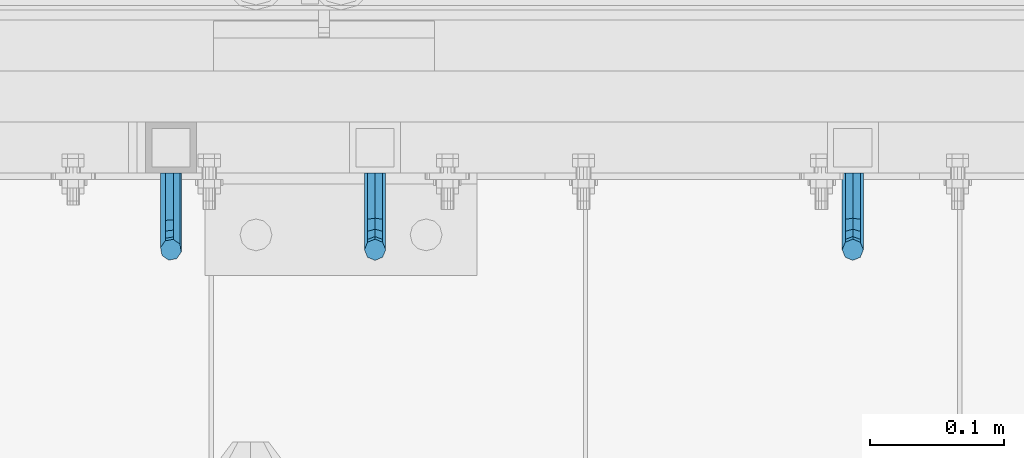
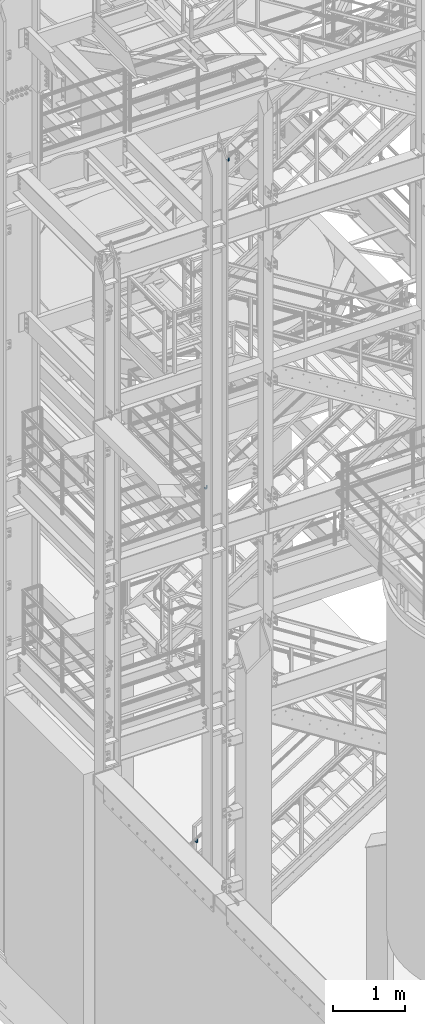
# One storey, part 1176 of 1876: 3 beams, 3 elements without a shape of their own.
"""IFC2X3 building model written with IfcOpenShell, lengths in millimetres."""

from ifc_helpers import new_model, si_unit, frame, origin_with_axes, place, context, subcontext, project, spatial, faceted_brep, material, type_object, element, aggregate, save


model = new_model("IFC2X3")

# Units and contexts
model_context = context("Model", 3, precision=1e-05, world=origin_with_axes())
body_context = subcontext(model_context, "Body", "Model", "MODEL_VIEW")
ifc_project = project(units=[si_unit("LENGTHUNIT", "METRE", prefix="MILLI"), si_unit("AREAUNIT", "SQUARE_METRE"), si_unit("VOLUMEUNIT", "CUBIC_METRE"), si_unit("MASSUNIT", "GRAM", prefix="KILO"), si_unit("TIMEUNIT", "SECOND"), si_unit("PLANEANGLEUNIT", "RADIAN"), si_unit("SOLIDANGLEUNIT", "STERADIAN"), si_unit("THERMODYNAMICTEMPERATUREUNIT", "DEGREE_CELSIUS"), si_unit("LUMINOUSINTENSITYUNIT", "LUMEN")], contexts=[model_context])

# Site, building, storey
site_placement = place(None, origin_with_axes())
site = spatial("IfcSite", under=ifc_project, at=site_placement, CompositionType="ELEMENT")
building_placement = place(site_placement, origin_with_axes())
building = spatial("IfcBuilding", under=site, at=building_placement, Name="Undefined", CompositionType="ELEMENT")
storey_placement = place(building_placement, origin_with_axes())
storey = spatial("IfcBuildingStorey", under=building, at=storey_placement, Name="Undefined", CompositionType="ELEMENT", Elevation=0.0)

# Assembly, beam
assembly_1_placement = place(storey_placement, origin_with_axes())
assembly_1 = element("IfcElementAssembly", 1, at=assembly_1_placement, inside=storey, Name="RAIL", AssemblyPlace="NOTDEFINED", PredefinedType="RIGID_FRAME")
ifc_material = material(Name="STEEL/A36")
beam_type = type_object("IfcBeamType", PredefinedType="NOTDEFINED")
beam_1_placement = place(assembly_1_placement, frame((3252.25833355881, -4800.59999885446, 12395.2930113215), z_axis=(1.0, 0.0, 0.0), x_axis=(0.0, -1.0, 0.0)))
beam_1 = element("IfcBeam", 2, at=beam_1_placement, type_object=beam_type, material=ifc_material, Name="BRACKET", context=body_context, shape_type="Brep", body=[
    faceted_brep([(0.0, -5.61266007566822, 5.61266007566883), (0.0, 0.0, 7.9375), (0.0, 5.61266007566822, 5.61266007566883), (0.0, 7.9375, 0.0), (0.0, 5.61266007566822, -5.61266007566883), (0.0, 0.0, -7.9375), (0.0, -5.61266007566822, -5.61266007566883), (0.0, -7.9375, 0.0), (23.8125, 5.61266007566883, 5.61266007566792), (23.8125, 7.9375, 0.0), (23.8125, 5.61266007566883, -5.61266007566792), (23.8125, 0.0, -7.9375), (23.8125, -5.61266007566883, -5.61266007566792), (23.8125, -7.9375, 0.0), (23.8125, -5.61266007566883, 5.61266007566792), (23.8125, 0.0, 7.9375), (36.5702095103989, -2.53766620105534, 7.9375), (38.7180815328547, 2.64775556579752, 5.61266007566792), (39.6077592547972, 4.79562758825296, 0.0), (38.7180815328547, 2.64775556579752, -5.61266007566792), (36.5702095103989, -2.53766620105534, -7.9375), (34.4223374879439, -7.72308796790867, -5.61266007566792), (33.5326597660014, -9.87095999036364, 0.0), (34.4223374879439, -7.72308796790867, 5.61266007566792), (43.4169233967659, -13.733078129113, 5.61266007566792), (47.385673396765, -9.76432812911298, 7.9375), (41.7730133210971, -15.3769882047809, 0.0), (43.4169233967659, -13.733078129113, -5.61266007566792), (47.385673396765, -9.76432812911298, -7.9375), (51.354423396765, -5.79557812911253, -5.61266007566792), (52.9983334724338, -4.15166805344461, 0.0), (51.354423396765, -5.79557812911253, 5.61266007566792), (54.6123353248231, -20.5797920154787, 7.9375), (59.7977570916764, -18.4319199930233, 5.61266007566792), (49.4269135579698, -22.7276640379341, 5.61266007566792), (47.2790415355148, -23.6173417598766, 0.0), (49.4269135579698, -22.7276640379341, -5.61266007566792), (54.6123353248231, -20.5797920154787, -7.9375), (59.7977570916764, -18.4319199930233, -5.61266007566792), (61.9456291141314, -17.5422422710808, 0.0), (62.7626616015468, -33.3375015258789, 5.61266007566792), (65.0875015258789, -33.3375015258789, 0.0), (57.1500015258789, -33.3375015258789, 7.9375), (51.5373414502101, -33.3375015258789, 5.61266007566792), (49.2125015258789, -33.3375015258789, 0.0), (51.5373414502101, -33.3375015258789, -5.61266007566792), (57.1500015258789, -33.3375015258789, -7.9375), (62.7626616015468, -33.3375015258789, -5.61266007566792), (65.0875015258789, -66.5341532333514, 2.45290721068159e-09), (62.7626616015805, -63.0815171359536, -5.61266007334871), (57.1500015259289, -61.6513884384531, -7.93749999776537), (51.5373414502437, -63.0815171359118, -5.6126600734151), (49.2125015258789, -66.5341532333259, 2.41197994910181e-09), (51.5373414501864, -69.9867893307037, 5.61266007818085), (57.1500015258471, -71.4169180281988, 7.93750000258842), (62.7626616015223, -69.9867893307346, 5.61266007822906)], [[[0, 1, 2, 3, 4, 5, 6, 7]], [[3, 2, 8, 9]], [[4, 3, 9, 10]], [[5, 4, 10, 11]], [[6, 5, 11, 12]], [[7, 6, 12, 13]], [[0, 7, 13, 14]], [[1, 0, 14, 15]], [[2, 1, 15, 8]], [[8, 15, 16, 17]], [[9, 8, 17, 18]], [[10, 9, 18, 19]], [[11, 10, 19, 20]], [[12, 11, 20, 21]], [[13, 12, 21, 22]], [[14, 13, 22, 23]], [[15, 14, 23, 16]], [[23, 24, 25, 16]], [[22, 26, 24, 23]], [[21, 27, 26, 22]], [[20, 28, 27, 21]], [[19, 29, 28, 20]], [[18, 30, 29, 19]], [[17, 31, 30, 18]], [[16, 25, 31, 17]], [[25, 32, 33, 31]], [[24, 34, 32, 25]], [[26, 35, 34, 24]], [[27, 36, 35, 26]], [[28, 37, 36, 27]], [[29, 38, 37, 28]], [[30, 39, 38, 29]], [[31, 33, 39, 30]], [[33, 40, 41, 39]], [[32, 42, 40, 33]], [[34, 43, 42, 32]], [[35, 44, 43, 34]], [[36, 45, 44, 35]], [[37, 46, 45, 36]], [[38, 47, 46, 37]], [[39, 41, 47, 38]], [[47, 41, 48, 49]], [[46, 47, 49, 50]], [[45, 46, 50, 51]], [[44, 45, 51, 52]], [[43, 44, 52, 53]], [[42, 43, 53, 54]], [[40, 42, 54, 55]], [[41, 40, 55, 48]], [[54, 53, 52, 51, 50, 49, 48, 55]]]),
])
aggregate(assembly_1, [beam_1])

assembly_2_placement = place(storey_placement, origin_with_axes())
assembly_2 = element("IfcElementAssembly", 3, at=assembly_2_placement, inside=storey, Name="RAIL", AssemblyPlace="NOTDEFINED", PredefinedType="RIGID_FRAME")
beam_2_placement = place(assembly_2_placement, frame((2895.60000031138, -4800.59999885446, 6951.80681178874), z_axis=(1.0, 0.0, 0.0), x_axis=(0.0, -1.0, 0.0)))
beam_2 = element("IfcBeam", 4, at=beam_2_placement, type_object=beam_type, material=ifc_material, Name="BRACKET", context=body_context, shape_type="Brep", body=[
    faceted_brep([(0.0, -5.61266007566822, 5.61266007566883), (0.0, 0.0, 7.9375), (0.0, 5.61266007566822, 5.61266007566883), (0.0, 7.9375, 0.0), (0.0, 5.61266007566822, -5.61266007566883), (0.0, 0.0, -7.9375), (0.0, -5.61266007566822, -5.61266007566883), (0.0, -7.9375, 0.0), (23.8125, 5.61266007566883, 5.61266007566792), (23.8125, 7.9375, 0.0), (23.8125, 5.61266007566883, -5.61266007566792), (23.8125, 0.0, -7.9375), (23.8125, -5.61266007566883, -5.61266007566792), (23.8125, -7.9375, 0.0), (23.8125, -5.61266007566883, 5.61266007566792), (23.8125, 0.0, 7.9375), (36.5702095103989, -2.53766620105534, 7.9375), (38.7180815328547, 2.64775556579752, 5.61266007566792), (39.6077592547972, 4.79562758825296, 0.0), (38.7180815328547, 2.64775556579752, -5.61266007566792), (36.5702095103989, -2.53766620105534, -7.9375), (34.4223374879439, -7.72308796790867, -5.61266007566792), (33.5326597660014, -9.87095999036364, 0.0), (34.4223374879439, -7.72308796790867, 5.61266007566792), (43.4169233967659, -13.733078129113, 5.61266007566792), (47.385673396765, -9.76432812911298, 7.9375), (41.7730133210971, -15.3769882047809, 0.0), (43.4169233967659, -13.733078129113, -5.61266007566792), (47.385673396765, -9.76432812911298, -7.9375), (51.354423396765, -5.79557812911253, -5.61266007566792), (52.9983334724338, -4.15166805344461, 0.0), (51.354423396765, -5.79557812911253, 5.61266007566792), (54.6123353248231, -20.5797920154787, 7.9375), (59.7977570916764, -18.4319199930233, 5.61266007566792), (49.4269135579698, -22.7276640379341, 5.61266007566792), (47.2790415355148, -23.6173417598766, 0.0), (49.4269135579698, -22.7276640379341, -5.61266007566792), (54.6123353248231, -20.5797920154787, -7.9375), (59.7977570916764, -18.4319199930233, -5.61266007566792), (61.9456291141314, -17.5422422710808, 0.0), (62.7626616015468, -33.3375015258789, 5.61266007566792), (65.0875015258789, -33.3375015258789, 0.0), (57.1500015258789, -33.3375015258789, 7.9375), (51.5373414502101, -33.3375015258789, 5.61266007566792), (49.2125015258789, -33.3375015258789, 0.0), (51.5373414502101, -33.3375015258789, -5.61266007566792), (57.1500015258789, -33.3375015258789, -7.9375), (62.7626616015468, -33.3375015258789, -5.61266007566792), (65.0875015258789, -66.3198535804604, 0.0), (62.7626616015468, -62.7481608643047, -5.61266007566792), (57.1500015258789, -61.2687173006434, -7.9375), (51.537341450211, -62.7481608643047, -5.61266007566792), (49.2125015258789, -66.3198535804604, 0.0), (51.537341450211, -69.8915462966161, 5.61266007566792), (57.1500015258789, -71.3709898602756, 7.9375), (62.7626616015468, -69.8915462966161, 5.61266007566792)], [[[0, 1, 2, 3, 4, 5, 6, 7]], [[3, 2, 8, 9]], [[4, 3, 9, 10]], [[5, 4, 10, 11]], [[6, 5, 11, 12]], [[7, 6, 12, 13]], [[0, 7, 13, 14]], [[1, 0, 14, 15]], [[2, 1, 15, 8]], [[8, 15, 16, 17]], [[9, 8, 17, 18]], [[10, 9, 18, 19]], [[11, 10, 19, 20]], [[12, 11, 20, 21]], [[13, 12, 21, 22]], [[14, 13, 22, 23]], [[15, 14, 23, 16]], [[23, 24, 25, 16]], [[22, 26, 24, 23]], [[21, 27, 26, 22]], [[20, 28, 27, 21]], [[19, 29, 28, 20]], [[18, 30, 29, 19]], [[17, 31, 30, 18]], [[16, 25, 31, 17]], [[25, 32, 33, 31]], [[24, 34, 32, 25]], [[26, 35, 34, 24]], [[27, 36, 35, 26]], [[28, 37, 36, 27]], [[29, 38, 37, 28]], [[30, 39, 38, 29]], [[31, 33, 39, 30]], [[33, 40, 41, 39]], [[32, 42, 40, 33]], [[34, 43, 42, 32]], [[35, 44, 43, 34]], [[36, 45, 44, 35]], [[37, 46, 45, 36]], [[38, 47, 46, 37]], [[39, 41, 47, 38]], [[47, 41, 48, 49]], [[46, 47, 49, 50]], [[45, 46, 50, 51]], [[44, 45, 51, 52]], [[43, 44, 52, 53]], [[42, 43, 53, 54]], [[40, 42, 54, 55]], [[41, 40, 55, 48]], [[54, 53, 52, 51, 50, 49, 48, 55]]]),
])
aggregate(assembly_2, [beam_2])

assembly_3_placement = place(storey_placement, origin_with_axes())
assembly_3 = element("IfcElementAssembly", 5, at=assembly_3_placement, inside=storey, Name="RAIL", AssemblyPlace="NOTDEFINED", PredefinedType="RIGID_FRAME")
beam_3_placement = place(assembly_3_placement, frame((2743.19999425942, -4800.59999885446, 1002.75259529631), z_axis=(0.844410015326383, 0.0, 0.535697420207059), x_axis=(0.0, -1.0, 0.0)))
beam_3 = element("IfcBeam", 6, at=beam_3_placement, type_object=beam_type, material=ifc_material, Name="BRACKET", context=body_context, shape_type="Brep", body=[
    faceted_brep([(0.0, -5.61266007566822, 5.61266007566883), (0.0, 0.0, 7.9375), (0.0, 5.61266007566822, 5.61266007566883), (0.0, 7.9375, 0.0), (0.0, 5.61266007566822, -5.61266007566883), (0.0, 0.0, -7.9375), (0.0, -5.61266007566822, -5.61266007566883), (0.0, -7.9375, 0.0), (25.7500019073486, 7.93750000000102, 9.09494701772928e-13), (25.7500019073486, 5.61266007566837, -5.61266007566837), (25.7500019073486, -6.82121026329696e-13, -7.93750000000091), (25.7500019073486, -5.6126600756694, -5.61266007566974), (25.7500019073486, -7.93750000000102, -1.81898940354586e-12), (25.7500019073486, -5.61266007566837, 5.61266007566746), (25.7500019073486, 6.82121026329696e-13, 7.93750000000045), (25.7500019073486, 5.6126600756694, 5.61266007566928), (38.4293366836664, 3.48299342205155, 6.96372994876174), (40.3311989638523, 5.48838972025123, 1.55372631168893), (40.7305556863994, 3.09647240503659, -4.01637957277262), (39.3934690994565, -2.29160580041184, -6.48369522136136), (37.103186391596, -7.51958175847221, -4.40290058978781), (35.20132411141, -9.5249780566719, 1.00710304728545), (34.8019673888657, -7.13306074145851, 6.57720893174746), (36.1390539758049, -1.74498253600871, 9.04452458033529), (44.9464670438292, -6.71427237123442, 12.1970638641865), (49.1783576787429, -2.58178409626339, 10.8112514273389), (42.4758531820917, -11.4627955199268, 9.32401168030583), (43.2137681863505, -14.0457330830792, 3.87508987960746), (46.7279514549882, -12.95003526696, -0.957797047369695), (50.9598420899019, -8.81754699198905, -2.34360948421772), (53.4304559516395, -4.06902384329646, 0.529442699663377), (52.6925409473806, -1.48608628014392, 5.97836450036175), (56.3606238862012, -11.6583650794599, 16.5694742441578), (60.952125596792, -11.9241272539106, 12.6003035112408), (50.8313923112155, -14.1513401749901, 16.9151723234295), (47.6033797389591, -17.942701540198, 13.4348925027043), (48.5675121547501, -20.8115211072019, 8.16733550011031), (53.159013865341, -21.0772832816523, 4.19816476719325), (58.6882454403267, -18.5843081861219, 3.85246668792206), (61.916258012584, -14.7929468209162, 7.33274650864814), (63.8525060225302, -24.2366360838653, 20.4114131579445), (64.8960754294303, -27.4426764670732, 15.3577905213597), (58.8827003833576, -22.3649223522546, 23.3617611737764), (52.8979032529824, -22.9239597913389, 22.4805607149005), (49.4039276223266, -25.5862718511769, 18.2840070589591), (50.4474970292276, -28.7923122343848, 13.2303844223738), (55.4173026683993, -30.6640259659952, 10.2800364065429), (61.4020997987745, -30.104988526911, 11.1612368654173), (64.8960754294312, -56.018050113816, 33.4861329926521), (61.4020997987755, -56.0180500190148, 27.6005968197555), (55.4173026684002, -56.018049999108, 26.364740543037), (50.4474970292276, -56.0180500657575, 30.5025120082541), (49.4039276223266, -56.01805017992, 37.5900608090838), (52.8979032529824, -56.0180502747214, 43.4755969819798), (58.8827003833576, -56.018050294628, 44.7114532586984), (63.8525060225302, -56.018050227979, 40.5736817934817)], [[[0, 1, 2, 3, 4, 5, 6, 7]], [[4, 3, 8, 9]], [[5, 4, 9, 10]], [[6, 5, 10, 11]], [[7, 6, 11, 12]], [[0, 7, 12, 13]], [[1, 0, 13, 14]], [[2, 1, 14, 15]], [[3, 2, 15, 8]], [[8, 15, 16, 17]], [[9, 8, 17, 18]], [[10, 9, 18, 19]], [[11, 10, 19, 20]], [[12, 11, 20, 21]], [[13, 12, 21, 22]], [[14, 13, 22, 23]], [[15, 14, 23, 16]], [[23, 24, 25, 16]], [[22, 26, 24, 23]], [[21, 27, 26, 22]], [[20, 28, 27, 21]], [[19, 29, 28, 20]], [[18, 30, 29, 19]], [[17, 31, 30, 18]], [[16, 25, 31, 17]], [[25, 32, 33, 31]], [[24, 34, 32, 25]], [[26, 35, 34, 24]], [[27, 36, 35, 26]], [[28, 37, 36, 27]], [[29, 38, 37, 28]], [[30, 39, 38, 29]], [[31, 33, 39, 30]], [[33, 40, 41, 39]], [[32, 42, 40, 33]], [[34, 43, 42, 32]], [[35, 44, 43, 34]], [[36, 45, 44, 35]], [[37, 46, 45, 36]], [[38, 47, 46, 37]], [[39, 41, 47, 38]], [[47, 41, 48, 49]], [[46, 47, 49, 50]], [[45, 46, 50, 51]], [[44, 45, 51, 52]], [[43, 44, 52, 53]], [[42, 43, 53, 54]], [[40, 42, 54, 55]], [[41, 40, 55, 48]], [[54, 53, 52, 51, 50, 49, 48, 55]]]),
])
aggregate(assembly_3, [beam_3])

save(model, "model.ifc")
